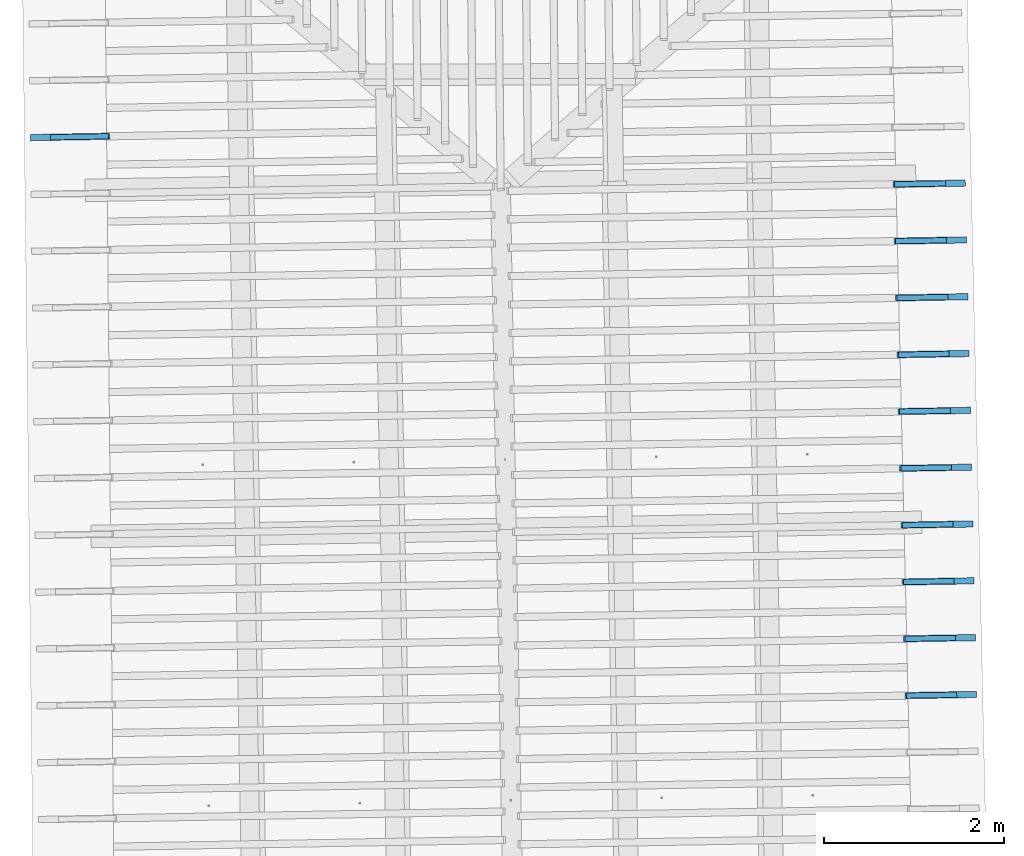
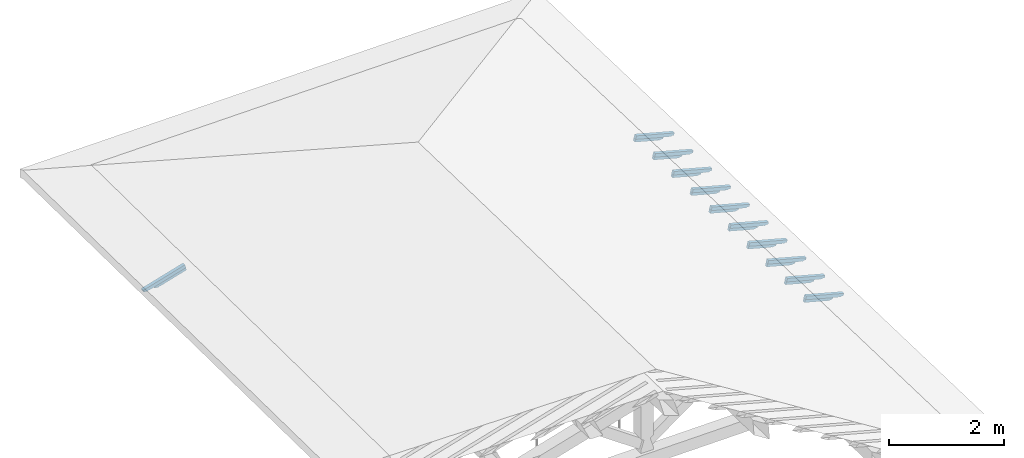
# One storey, part 14 of 19: 22 beams, 4 elements without a shape of their own.
"""IFC4 building model written with IfcOpenShell, lengths in metres."""

from ifc_helpers import new_model, entity, si_unit, converted_unit, derived_unit, direction, frame, origin, place, context, subcontext, project, spatial, line, arc, indexed_curve, outline, extrude, source, transform, mapped, material, type_object, type_shapes, element, aggregate, save


model = new_model("IFC4")

# Units and contexts
model_context = context("Model", 3, precision=1e-05, world=origin(), true_north=direction((6.123233995736766e-17, 1.0)))
body_context = subcontext(model_context, "Body", "Model", "MODEL_VIEW")
ifc_project = project(units=[si_unit("LENGTHUNIT", "METRE"), si_unit("AREAUNIT", "SQUARE_METRE"), si_unit("VOLUMEUNIT", "CUBIC_METRE"), converted_unit("PLANEANGLEUNIT", "DEGREE", entity("IfcPlaneAngleMeasure", 0.017453292519943278), si_unit("PLANEANGLEUNIT", "RADIAN"), dimensions=[0, 0, 0, 0, 0, 0, 0]), derived_unit("THERMALTRANSMITTANCEUNIT", [(si_unit("MASSUNIT", "GRAM", prefix="KILO"), 1), (si_unit("THERMODYNAMICTEMPERATUREUNIT", "KELVIN"), -1), (si_unit("TIMEUNIT", "SECOND"), -3)])], contexts=[model_context])

# Site, building, storey
site_placement = place(None, origin())
site = spatial("IfcSite", under=ifc_project, at=site_placement, CompositionType="ELEMENT")
building_placement = place(site_placement, origin())
building = spatial("IfcBuilding", under=site, at=building_placement, CompositionType="ELEMENT")
storey_placement = place(building_placement, frame((0.0, 0.0, 3.28)))
storey = spatial("IfcBuildingStorey", under=building, at=storey_placement, Name="Livello Copertura", CompositionType="ELEMENT", Elevation=3.28)

# Assembly, beam
assembly_1_placement = place(storey_placement, origin())
assembly_1 = element("IfcElementAssembly", 1, at=assembly_1_placement, inside=storey, Name="Sistema di travi strutturali:Sistema di travi strutturali", ObjectType="Sistema di travi strutturali:Sistema di travi strutturali", AssemblyPlace="NOTDEFINED", PredefinedType="BEAM_GRID")
ifc_material = material(Name="Legno - Legno da costruzione", Category="Legno")
beam_type_1 = type_object("IfcBeamType", Name="70x70:70x70", PredefinedType="JOIST", material=ifc_material)
shared_shape_1 = source(origin(), body_context, "Body", "SweptSolid", [
    extrude(outline(indexed_curve([(-0.04357142857143151, -0.5911428571428567), (0.026428571428568484, -0.5911428571428567), (0.026428571428568484, 0.1868571428571434), (0.012428571428584384, 0.18685714285714), (0.026181867029378903, 0.21056674738504463), (0.01842857142857075, 0.23685714285714354), (0.006014118110847714, 0.2598527183721264), (0.0034285714285709197, 0.28585714285714336), (-0.04357142857143151, 0.28585714285714336)], segments=[line(1, 2, 3, 4), arc(4, 5, 6), arc(6, 7, 8), line(8, 9, 1)], self_intersect=False)), frame((-0.11764285714285669, -0.03500000000000078, -0.008571428571433238), z_axis=(0.0, 1.0, 0.0), x_axis=(0.0, 0.0, -1.0)), (0.0, 0.0, 1.0), 0.06999999999999999),
])
type_shapes(beam_type_1, [shared_shape_1])
beam_1_placement = place(assembly_1_placement, frame((-5.117563232608936, 12.887914730478428, 0.11938629617812602), z_axis=(-0.26888056974925323, -0.004594467440668784, 0.9631625667976583), x_axis=(0.9630219859926786, 0.016455533263033686, 0.2689198206152652)))
beam_1 = element("IfcBeam", 2, at=beam_1_placement, type_object=beam_type_1, material=ifc_material, Name="70x70:70x70", ObjectType="70x70:70x70", PredefinedType="JOIST", context=body_context, shape_type="MappedRepresentation", body=[
    mapped(shared_shape_1, transform((0.0, 0.0, 0.0), scale=1.0)),
])
aggregate(assembly_1, [beam_1])

assembly_2_placement = place(storey_placement, origin())
assembly_2 = element("IfcElementAssembly", 3, at=assembly_2_placement, inside=storey, Name="Sistema di travi strutturali:Sistema di travi strutturali", ObjectType="Sistema di travi strutturali:Sistema di travi strutturali", AssemblyPlace="NOTDEFINED", PredefinedType="BEAM_GRID")
beam_type_2 = type_object("IfcBeamType", Name="60x60:60x60", PredefinedType="JOIST", material=ifc_material)
shared_shape_2 = source(origin(), body_context, "Body", "SweptSolid", [
    extrude(outline(indexed_curve([(-0.03585714285711799, -0.43985714285714317), (0.02414285714288199, -0.43985714285714317), (0.02414285714288199, 0.12814285714285706), (0.007142857142882057, 0.12814285714285706), (0.022800314198398987, 0.14573927319842478), (0.02014285714279457, 0.16914285714285818), (0.006097362558745775, 0.19729644559083798), (-0.003857142857204642, 0.227142857142857), (-0.03585714285711799, 0.2271428571428571)], segments=[line(1, 2, 3, 4), arc(4, 5, 6), arc(6, 7, 8), line(8, 9, 1)], self_intersect=False)), frame((0.03364285714285701, -0.030000000000000786, -0.005857142857119723), z_axis=(0.0, 1.0, 0.0), x_axis=(0.0, 0.0, -1.0)), (0.0, 0.0, 1.0), 0.059999999999999984),
])
type_shapes(beam_type_2, [shared_shape_2])
beam_2_placement = place(assembly_2_placement, frame((-5.100085995575236, 12.888213370862069, 0.056780729336277425), z_axis=(-0.26888056974925323, -0.004594467440668784, 0.9631625667976583), x_axis=(0.9630219859926786, 0.016455533263033686, 0.2689198206152652)))
beam_2 = element("IfcBeam", 4, at=beam_2_placement, type_object=beam_type_2, material=ifc_material, Name="60x60:60x60", ObjectType="60x60:60x60", PredefinedType="JOIST", context=body_context, shape_type="MappedRepresentation", body=[
    mapped(shared_shape_2, transform((0.0, 0.0, 0.0), scale=1.0)),
])
aggregate(assembly_2, [beam_2])

# Assembly, beams
assembly_3_placement = place(storey_placement, origin())
assembly_3 = element("IfcElementAssembly", 5, at=assembly_3_placement, inside=storey, Name="Sistema di travi strutturali:Sistema di travi strutturali", ObjectType="Sistema di travi strutturali:Sistema di travi strutturali", AssemblyPlace="NOTDEFINED", PredefinedType="BEAM_GRID")
beam_type_3 = type_object("IfcBeamType", Name="70x70:70x70", PredefinedType="JOIST", material=ifc_material)
shared_shape_3 = source(origin(), body_context, "Body", "SweptSolid", [
    extrude(outline(indexed_curve([(-0.043571428571431474, -0.5339999999999995), (0.026428571428568515, -0.5339999999999995), (0.026428571428568515, 0.16400000000000048), (0.012428571428584417, 0.1639999999999971), (0.02618186702937893, 0.18770960452790172), (0.018428571428570663, 0.21400000000000063), (0.006014118110847628, 0.23699557551498354), (0.0034285714285708334, 0.26300000000000046), (-0.043571428571431474, 0.26300000000000046)], segments=[line(1, 2, 3, 4), arc(4, 5, 6), arc(6, 7, 8), line(8, 9, 1)], self_intersect=False)), frame((-0.1004999999999995, -0.03500000000000078, -0.008571428571433207), z_axis=(0.0, 1.0, 0.0), x_axis=(0.0, 0.0, -1.0)), (0.0, 0.0, 1.0), 0.06999999999999999),
])
type_shapes(beam_type_3, [shared_shape_3])
beam_3_placement = place(assembly_3_placement, frame((4.4886432946279005, 12.371057575001064, 0.12287253880867066), z_axis=(0.2688805697492533, 0.004594467440668769, 0.9631625667976583), x_axis=(-0.9630219859926786, -0.016455533263030984, 0.2689198206152652)))
beam_3 = element("IfcBeam", 6, at=beam_3_placement, type_object=beam_type_3, material=ifc_material, Name="70x70:70x70", ObjectType="70x70:70x70", PredefinedType="JOIST", context=body_context, shape_type="MappedRepresentation", body=[
    mapped(shared_shape_3, transform((0.0, 0.0, 0.0), scale=1.0)),
])
beam_type_4 = type_object("IfcBeamType", Name="70x70:70x70", PredefinedType="JOIST", material=ifc_material)
shared_shape_4 = source(origin(), body_context, "Body", "SweptSolid", [
    extrude(outline(indexed_curve([(-0.04357142857143146, -0.5332857142857139), (0.026428571428568533, -0.5332857142857139), (0.026428571428568533, 0.16371428571428626), (0.012428571428584435, 0.16371428571428281), (0.026181867029378948, 0.18742389024218745), (0.018428571428570628, 0.2137142857142864), (0.006014118110847594, 0.23670986122926932), (0.003428571428570799, 0.26271428571428623), (-0.04357142857143146, 0.26271428571428623)], segments=[line(1, 2, 3, 4), arc(4, 5, 6), arc(6, 7, 8), line(8, 9, 1)], self_intersect=False)), frame((-0.10028571428571384, -0.03500000000000078, -0.00857142857143319), z_axis=(0.0, 1.0, 0.0), x_axis=(0.0, 0.0, -1.0)), (0.0, 0.0, 1.0), 0.06999999999999999),
])
type_shapes(beam_type_4, [shared_shape_4])
beam_4_placement = place(assembly_3_placement, frame((4.503091301204321, 11.74121248708805, 0.12184365175980783), z_axis=(0.2688805697492532, 0.0045944674406687685, 0.9631625667976583), x_axis=(-0.9630219859926786, -0.01645553326303173, 0.2689198206152651)))
beam_4 = element("IfcBeam", 7, at=beam_4_placement, type_object=beam_type_4, material=ifc_material, Name="70x70:70x70", ObjectType="70x70:70x70", PredefinedType="JOIST", context=body_context, shape_type="MappedRepresentation", body=[
    mapped(shared_shape_4, transform((0.0, 0.0, 0.0), scale=1.0)),
])
beam_5_placement = place(assembly_3_placement, frame((4.517539307780747, 11.111367399175041, 0.12081476471094454), z_axis=(0.26888056974925423, 0.004594467440668786, 0.9631625667976581), x_axis=(-0.9630219859926783, -0.0164555332630325, 0.26891982061526615)))
beam_5 = element("IfcBeam", 8, at=beam_5_placement, type_object=beam_type_4, material=ifc_material, Name="70x70:70x70", ObjectType="70x70:70x70", PredefinedType="JOIST", context=body_context, shape_type="MappedRepresentation", body=[
    mapped(shared_shape_4, transform((0.0, 0.0, 0.0), scale=1.0)),
])
beam_type_5 = type_object("IfcBeamType", Name="70x70:70x70", PredefinedType="JOIST", material=ifc_material)
shared_shape_5 = source(origin(), body_context, "Body", "SweptSolid", [
    extrude(outline(indexed_curve([(-0.043571428571431474, -0.5325714285714281), (0.026428571428568515, -0.5325714285714281), (0.026428571428568515, 0.16342857142857198), (0.012428571428584417, 0.1634285714285686), (0.02618186702937893, 0.18713817595647322), (0.018428571428570663, 0.2134285714285721), (0.006014118110847628, 0.236424146943555), (0.0034285714285708334, 0.26242857142857196), (-0.043571428571431474, 0.26242857142857196)], segments=[line(1, 2, 3, 4), arc(4, 5, 6), arc(6, 7, 8), line(8, 9, 1)], self_intersect=False)), frame((-0.1000714285714281, -0.03500000000000078, -0.008571428571433207), z_axis=(0.0, 1.0, 0.0), x_axis=(0.0, 0.0, -1.0)), (0.0, 0.0, 1.0), 0.06999999999999999),
])
type_shapes(beam_type_5, [shared_shape_5])
beam_6_placement = place(assembly_3_placement, frame((4.5319873143571705, 10.481522311262026, 0.11978587766208082), z_axis=(0.26888056974925306, 0.0045944674406687685, 0.9631625667976583), x_axis=(-0.9630219859926786, -0.01645553326303327, 0.26891982061526504)))
beam_6 = element("IfcBeam", 9, at=beam_6_placement, type_object=beam_type_5, material=ifc_material, Name="70x70:70x70", ObjectType="70x70:70x70", PredefinedType="JOIST", context=body_context, shape_type="MappedRepresentation", body=[
    mapped(shared_shape_5, transform((0.0, 0.0, 0.0), scale=1.0)),
])
beam_type_6 = type_object("IfcBeamType", Name="70x70:70x70", PredefinedType="JOIST", material=ifc_material)
shared_shape_6 = source(origin(), body_context, "Body", "SweptSolid", [
    extrude(outline(indexed_curve([(-0.04357142857143147, -0.5318571428571425), (0.026428571428568526, -0.5318571428571425), (0.026428571428568526, 0.16314285714285764), (0.012428571428584428, 0.16314285714285426), (0.026181867029378945, 0.18685246167075892), (0.01842857142857064, 0.2131428571428578), (0.006014118110847603, 0.2361384326578407), (0.0034285714285708087, 0.2621428571428576), (-0.04357142857143147, 0.2621428571428576)], segments=[line(1, 2, 3, 4), arc(4, 5, 6), arc(6, 7, 8), line(8, 9, 1)], self_intersect=False)), frame((-0.0998571428571424, -0.03500000000000078, -0.008571428571433197), z_axis=(0.0, 1.0, 0.0), x_axis=(0.0, 0.0, -1.0)), (0.0, 0.0, 1.0), 0.06999999999999999),
])
type_shapes(beam_type_6, [shared_shape_6])
beam_7_placement = place(assembly_3_placement, frame((4.546435320933593, 9.851677223349013, 0.1187569906132171), z_axis=(0.26888056974925306, 0.004594467440668767, 0.9631625667976583), x_axis=(-0.9630219859926786, -0.01645553326303402, 0.26891982061526504)))
beam_7 = element("IfcBeam", 10, at=beam_7_placement, type_object=beam_type_6, material=ifc_material, Name="70x70:70x70", ObjectType="70x70:70x70", PredefinedType="JOIST", context=body_context, shape_type="MappedRepresentation", body=[
    mapped(shared_shape_6, transform((0.0, 0.0, 0.0), scale=1.0)),
])
beam_type_7 = type_object("IfcBeamType", Name="70x70:70x70", PredefinedType="JOIST", material=ifc_material)
shared_shape_7 = source(origin(), body_context, "Body", "SweptSolid", [
    extrude(outline(indexed_curve([(-0.043571428571431516, -0.5311428571428567), (0.026428571428568474, -0.5311428571428567), (0.026428571428568474, 0.16285714285714334), (0.01242857142858438, 0.16285714285713995), (0.0261818670293789, 0.18656674738504458), (0.01842857142857076, 0.21285714285714347), (0.006014118110847725, 0.23585271837212637), (0.0034285714285709305, 0.2618571428571433), (-0.043571428571431516, 0.2618571428571433)], segments=[line(1, 2, 3, 4), arc(4, 5, 6), arc(6, 7, 8), line(8, 9, 1)], self_intersect=False)), frame((-0.09964285714285667, -0.03500000000000078, -0.008571428571433245), z_axis=(0.0, 1.0, 0.0), x_axis=(0.0, 0.0, -1.0)), (0.0, 0.0, 1.0), 0.06999999999999999),
])
type_shapes(beam_type_7, [shared_shape_7])
beam_8_placement = place(assembly_3_placement, frame((4.560883327510016, 9.221832135436001, 0.11772810356435515), z_axis=(0.2688805697492532, 0.0045944674406687685, 0.9631625667976583), x_axis=(-0.9630219859926786, -0.016455533263032313, 0.2689198206152651)))
beam_8 = element("IfcBeam", 11, at=beam_8_placement, type_object=beam_type_7, material=ifc_material, Name="70x70:70x70", ObjectType="70x70:70x70", PredefinedType="JOIST", context=body_context, shape_type="MappedRepresentation", body=[
    mapped(shared_shape_7, transform((0.0, 0.0, 0.0), scale=1.0)),
])
beam_9_placement = place(assembly_3_placement, frame((4.57533133408644, 8.591987047522988, 0.1166992165154912), z_axis=(0.26888056974925273, 0.00459446744066876, 0.9631625667976585), x_axis=(-0.9630219859926787, -0.01645553326303308, 0.26891982061526465)))
beam_9 = element("IfcBeam", 12, at=beam_9_placement, type_object=beam_type_7, material=ifc_material, Name="70x70:70x70", ObjectType="70x70:70x70", PredefinedType="JOIST", context=body_context, shape_type="MappedRepresentation", body=[
    mapped(shared_shape_7, transform((0.0, 0.0, 0.0), scale=1.0)),
])
beam_type_8 = type_object("IfcBeamType", Name="70x70:70x70", PredefinedType="JOIST", material=ifc_material)
shared_shape_8 = source(origin(), body_context, "Body", "SweptSolid", [
    extrude(outline(indexed_curve([(-0.04357142857143147, -0.5304285714285708), (0.0264285714285685, -0.5304285714285708), (0.0264285714285685, 0.16257142857142903), (0.012428571428584383, 0.16257142857142565), (0.0261818670293789, 0.1862810330993303), (0.018428571428570684, 0.2125714285714292), (0.006014118110847649, 0.2355670040864121), (0.003428571428570854, 0.261571428571429), (-0.04357142857143147, 0.261571428571429)], segments=[line(1, 2, 3, 4), arc(4, 5, 6), arc(6, 7, 8), line(8, 9, 1)], self_intersect=False)), frame((-0.09942857142857084, -0.03500000000000078, -0.00857142857143322), z_axis=(0.0, 1.0, 0.0), x_axis=(0.0, 0.0, -1.0)), (0.0, 0.0, 1.0), 0.06999999999999999),
])
type_shapes(beam_type_8, [shared_shape_8])
beam_10_placement = place(assembly_3_placement, frame((4.589779340662864, 7.962141959609977, 0.11567032946662792), z_axis=(0.26888056974925384, 0.004594467440668779, 0.9631625667976582), x_axis=(-0.9630219859926784, -0.016455533263032607, 0.26891982061526576)))
beam_10 = element("IfcBeam", 13, at=beam_10_placement, type_object=beam_type_8, material=ifc_material, Name="70x70:70x70", ObjectType="70x70:70x70", PredefinedType="JOIST", context=body_context, shape_type="MappedRepresentation", body=[
    mapped(shared_shape_8, transform((0.0, 0.0, 0.0), scale=1.0)),
])
beam_type_9 = type_object("IfcBeamType", Name="70x70:70x70", PredefinedType="JOIST", material=ifc_material)
shared_shape_9 = source(origin(), body_context, "Body", "SweptSolid", [
    extrude(outline(indexed_curve([(-0.04357142857143152, -0.5297142857142852), (0.026428571428568467, -0.5297142857142852), (0.026428571428568467, 0.16228571428571475), (0.012428571428584369, 0.16228571428571142), (0.026181867029378886, 0.18599531881361608), (0.018428571428570784, 0.21228571428571488), (0.006014118110847748, 0.2352812898006978), (0.003428571428570954, 0.26128571428571473), (-0.04357142857143152, 0.26128571428571473)], segments=[line(1, 2, 3, 4), arc(4, 5, 6), arc(6, 7, 8), line(8, 9, 1)], self_intersect=False)), frame((-0.09921428571428524, -0.03500000000000078, -0.008571428571433256), z_axis=(0.0, 1.0, 0.0), x_axis=(0.0, 0.0, -1.0)), (0.0, 0.0, 1.0), 0.06999999999999999),
])
type_shapes(beam_type_9, [shared_shape_9])
beam_11_placement = place(assembly_3_placement, frame((4.604227347239287, 7.3322968716969665, 0.11464144241776353), z_axis=(0.26888056974925284, 0.0045944674406687615, 0.9631625667976584), x_axis=(-0.9630219859926787, -0.016455533263032122, 0.26891982061526476)))
beam_11 = element("IfcBeam", 14, at=beam_11_placement, type_object=beam_type_9, material=ifc_material, Name="70x70:70x70", ObjectType="70x70:70x70", PredefinedType="JOIST", context=body_context, shape_type="MappedRepresentation", body=[
    mapped(shared_shape_9, transform((0.0, 0.0, 0.0), scale=1.0)),
])
beam_type_10 = type_object("IfcBeamType", Name="70x70:70x70", PredefinedType="JOIST", material=ifc_material)
shared_shape_10 = source(origin(), body_context, "Body", "SweptSolid", [
    extrude(outline(indexed_curve([(-0.043571428571431495, -0.5289999999999996), (0.026428571428568474, -0.5289999999999996), (0.026428571428568474, 0.1620000000000005), (0.01242857142858435, 0.16199999999999715), (0.026181867029378865, 0.18570960452790178), (0.018428571428570757, 0.21200000000000063), (0.006014118110847721, 0.23499557551498354), (0.003428571428570926, 0.26100000000000045), (-0.043571428571431495, 0.26100000000000045)], segments=[line(1, 2, 3, 4), arc(4, 5, 6), arc(6, 7, 8), line(8, 9, 1)], self_intersect=False)), frame((-0.09899999999999946, -0.03500000000000078, -0.008571428571433249), z_axis=(0.0, 1.0, 0.0), x_axis=(0.0, 0.0, -1.0)), (0.0, 0.0, 1.0), 0.06999999999999999),
])
type_shapes(beam_type_10, [shared_shape_10])
beam_12_placement = place(assembly_3_placement, frame((4.618675353815711, 6.702451783783954, 0.11361255536890003), z_axis=(0.2688805697492532, 0.0045944674406687685, 0.9631625667976583), x_axis=(-0.9630219859926786, -0.01645553326303164, 0.26891982061526515)))
beam_12 = element("IfcBeam", 15, at=beam_12_placement, type_object=beam_type_10, material=ifc_material, Name="70x70:70x70", ObjectType="70x70:70x70", PredefinedType="JOIST", context=body_context, shape_type="MappedRepresentation", body=[
    mapped(shared_shape_10, transform((0.0, 0.0, 0.0), scale=1.0)),
])
aggregate(assembly_3, [beam_3, beam_4, beam_5, beam_6, beam_7, beam_8, beam_9, beam_10, beam_11, beam_12])

assembly_4_placement = place(storey_placement, origin())
assembly_4 = element("IfcElementAssembly", 16, at=assembly_4_placement, inside=storey, Name="Sistema di travi strutturali:Sistema di travi strutturali", ObjectType="Sistema di travi strutturali:Sistema di travi strutturali", AssemblyPlace="NOTDEFINED", PredefinedType="BEAM_GRID")
beam_type_11 = type_object("IfcBeamType", Name="60x60:60x60", PredefinedType="JOIST", material=ifc_material)
shared_shape_11 = source(origin(), body_context, "Body", "SweptSolid", [
    extrude(outline(indexed_curve([(-0.03585714285711755, -0.38271428571428584), (0.02414285714288243, -0.38271428571428584), (0.02414285714288243, 0.10528571428571411), (0.007142857142882492, 0.10528571428571411), (0.022800314198399424, 0.12288213034128184), (0.020142857142793485, 0.14628571428571524), (0.006097362558744688, 0.174439302733695), (-0.0038571428572057287, 0.20428571428571407), (-0.03585714285711755, 0.20428571428571413)], segments=[line(1, 2, 3, 4), arc(4, 5, 6), arc(6, 7, 8), line(8, 9, 1)], self_intersect=False)), frame((0.05078571428571418, -0.030000000000000786, -0.005857142857119288), z_axis=(0.0, 1.0, 0.0), x_axis=(0.0, 0.0, -1.0)), (0.0, 0.0, 1.0), 0.059999999999999984),
])
type_shapes(beam_type_11, [shared_shape_11])
beam_13_placement = place(assembly_4_placement, frame((4.471166057594199, 12.370758934617422, 0.060266971966822735), z_axis=(0.2688805697492535, 0.004594467440668775, 0.9631625667976582), x_axis=(-0.9630219859926786, -0.01645553326303096, 0.2689198206152655)))
beam_13 = element("IfcBeam", 17, at=beam_13_placement, type_object=beam_type_11, material=ifc_material, Name="60x60:60x60", ObjectType="60x60:60x60", PredefinedType="JOIST", context=body_context, shape_type="MappedRepresentation", body=[
    mapped(shared_shape_11, transform((0.0, 0.0, 0.0), scale=1.0)),
])
beam_type_12 = type_object("IfcBeamType", Name="60x60:60x60", PredefinedType="JOIST", material=ifc_material)
shared_shape_12 = source(origin(), body_context, "Body", "SweptSolid", [
    extrude(outline(indexed_curve([(-0.03585714285711767, -0.3820000000000003), (0.024142857142882314, -0.3820000000000003), (0.024142857142882314, 0.10499999999999989), (0.007142857142882376, 0.10499999999999989), (0.02280031419839931, 0.12259641605556762), (0.020142857142793777, 0.14600000000000102), (0.006097362558744978, 0.17415358844798082), (-0.003857142857205439, 0.20399999999999985), (-0.03585714285711767, 0.20399999999999993)], segments=[line(1, 2, 3, 4), arc(4, 5, 6), arc(6, 7, 8), line(8, 9, 1)], self_intersect=False)), frame((0.050999999999999844, -0.030000000000000786, -0.005857142857119404), z_axis=(0.0, 1.0, 0.0), x_axis=(0.0, 0.0, -1.0)), (0.0, 0.0, 1.0), 0.059999999999999984),
])
type_shapes(beam_type_12, [shared_shape_12])
beam_14_placement = place(assembly_4_placement, frame((4.485614064170621, 11.740913846704409, 0.05923808491796012), z_axis=(0.2688805697492532, 0.0045944674406687685, 0.9631625667976583), x_axis=(-0.9630219859926786, -0.01645553326303173, 0.2689198206152651)))
beam_14 = element("IfcBeam", 18, at=beam_14_placement, type_object=beam_type_12, material=ifc_material, Name="60x60:60x60", ObjectType="60x60:60x60", PredefinedType="JOIST", context=body_context, shape_type="MappedRepresentation", body=[
    mapped(shared_shape_12, transform((0.0, 0.0, 0.0), scale=1.0)),
])
beam_15_placement = place(assembly_4_placement, frame((4.5000620707470445, 11.111068758791392, 0.05820919786909662), z_axis=(0.2688805697492538, 0.004594467440668778, 0.9631625667976582), x_axis=(-0.9630219859926785, -0.016455533263032514, 0.26891982061526576)))
beam_15 = element("IfcBeam", 19, at=beam_15_placement, type_object=beam_type_12, material=ifc_material, Name="60x60:60x60", ObjectType="60x60:60x60", PredefinedType="JOIST", context=body_context, shape_type="MappedRepresentation", body=[
    mapped(shared_shape_12, transform((0.0, 0.0, 0.0), scale=1.0)),
])
beam_type_13 = type_object("IfcBeamType", Name="60x60:60x60", PredefinedType="JOIST", material=ifc_material)
shared_shape_13 = source(origin(), body_context, "Body", "SweptSolid", [
    extrude(outline(indexed_curve([(-0.035857142857117746, -0.3812857142857145), (0.024142857142882237, -0.3812857142857145), (0.024142857142882237, 0.1047142857142856), (0.007142857142882299, 0.1047142857142856), (0.022800314198399233, 0.12231070176985331), (0.02014285714279397, 0.14571428571428674), (0.006097362558745171, 0.1738678741622665), (-0.0038571428572052456, 0.20371428571428557), (-0.035857142857117746, 0.20371428571428563)], segments=[line(1, 2, 3, 4), arc(4, 5, 6), arc(6, 7, 8), line(8, 9, 1)], self_intersect=False)), frame((0.051214285714285566, -0.030000000000000786, -0.005857142857119481), z_axis=(0.0, 1.0, 0.0), x_axis=(0.0, 0.0, -1.0)), (0.0, 0.0, 1.0), 0.059999999999999984),
])
type_shapes(beam_type_13, [shared_shape_13])
beam_16_placement = place(assembly_4_placement, frame((4.51451007732347, 10.481223670878382, 0.057180310820233116), z_axis=(0.2688805697492537, 0.004594467440668775, 0.9631625667976583), x_axis=(-0.9630219859926785, -0.016455533263033256, 0.2689198206152656)))
beam_16 = element("IfcBeam", 20, at=beam_16_placement, type_object=beam_type_13, material=ifc_material, Name="60x60:60x60", ObjectType="60x60:60x60", PredefinedType="JOIST", context=body_context, shape_type="MappedRepresentation", body=[
    mapped(shared_shape_13, transform((0.0, 0.0, 0.0), scale=1.0)),
])
beam_type_14 = type_object("IfcBeamType", Name="60x60:60x60", PredefinedType="JOIST", material=ifc_material)
shared_shape_14 = source(origin(), body_context, "Body", "SweptSolid", [
    extrude(outline(indexed_curve([(-0.035857142857116775, -0.38057142857142884), (0.024142857142883205, -0.38057142857142884), (0.024142857142883205, 0.10442857142857137), (0.007142857142883392, 0.10442857142857148), (0.022800314198400326, 0.12202498748413922), (0.020142857142791487, 0.14542857142857227), (0.0060973625587426895, 0.17358215987655207), (-0.0038571428572077276, 0.2034285714285711), (-0.035857142857116775, 0.2034285714285715)], segments=[line(1, 2, 3, 4), arc(4, 5, 6), arc(6, 7, 8), line(8, 9, 1)], self_intersect=False)), frame((0.05142857142857124, -0.030000000000000786, -0.005857142857118512), z_axis=(0.0, 1.0, 0.0), x_axis=(0.0, 0.0, -1.0)), (0.0, 0.0, 1.0), 0.059999999999999984),
])
type_shapes(beam_type_14, [shared_shape_14])
beam_17_placement = place(assembly_4_placement, frame((4.528958083899893, 9.851378582965374, 0.05615142377136917), z_axis=(0.26888056974925334, 0.0045944674406687685, 0.9631625667976584), x_axis=(-0.9630219859926786, -0.016455533263034065, 0.26891982061526526)))
beam_17 = element("IfcBeam", 21, at=beam_17_placement, type_object=beam_type_14, material=ifc_material, Name="60x60:60x60", ObjectType="60x60:60x60", PredefinedType="JOIST", context=body_context, shape_type="MappedRepresentation", body=[
    mapped(shared_shape_14, transform((0.0, 0.0, 0.0), scale=1.0)),
])
beam_type_15 = type_object("IfcBeamType", Name="60x60:60x60", PredefinedType="JOIST", material=ifc_material)
shared_shape_15 = source(origin(), body_context, "Body", "SweptSolid", [
    extrude(outline(indexed_curve([(-0.035857142857117975, -0.379857142857143), (0.024142857142882005, -0.379857142857143), (0.024142857142882005, 0.10414285714285698), (0.007142857142882067, 0.10414285714285698), (0.022800314198399, 0.12173927319842472), (0.02014285714279455, 0.14514285714285813), (0.006097362558745752, 0.1732964455908379), (-0.003857142857204665, 0.20314285714285696), (-0.035857142857117975, 0.20314285714285701)], segments=[line(1, 2, 3, 4), arc(4, 5, 6), arc(6, 7, 8), line(8, 9, 1)], self_intersect=False)), frame((0.05164285714285701, -0.030000000000000786, -0.005857142857119713), z_axis=(0.0, 1.0, 0.0), x_axis=(0.0, 0.0, -1.0)), (0.0, 0.0, 1.0), 0.059999999999999984),
])
type_shapes(beam_type_15, [shared_shape_15])
beam_18_placement = place(assembly_4_placement, frame((4.543406090476315, 9.221533495052359, 0.055122536722506776), z_axis=(0.2688805697492532, 0.00459446744066877, 0.9631625667976583), x_axis=(-0.9630219859926786, -0.016455533263032313, 0.2689198206152651)))
beam_18 = element("IfcBeam", 22, at=beam_18_placement, type_object=beam_type_15, material=ifc_material, Name="60x60:60x60", ObjectType="60x60:60x60", PredefinedType="JOIST", context=body_context, shape_type="MappedRepresentation", body=[
    mapped(shared_shape_15, transform((0.0, 0.0, 0.0), scale=1.0)),
])
beam_19_placement = place(assembly_4_placement, frame((4.557854097052738, 8.591688407139348, 0.05409364967364283), z_axis=(0.2688805697492535, 0.004594467440668775, 0.9631625667976582), x_axis=(-0.9630219859926785, -0.016455533263031837, 0.2689198206152654)))
beam_19 = element("IfcBeam", 23, at=beam_19_placement, type_object=beam_type_15, material=ifc_material, Name="60x60:60x60", ObjectType="60x60:60x60", PredefinedType="JOIST", context=body_context, shape_type="MappedRepresentation", body=[
    mapped(shared_shape_15, transform((0.0, 0.0, 0.0), scale=1.0)),
])
beam_type_16 = type_object("IfcBeamType", Name="60x60:60x60", PredefinedType="JOIST", material=ifc_material)
shared_shape_16 = source(origin(), body_context, "Body", "SweptSolid", [
    extrude(outline(indexed_curve([(-0.03585714285711765, -0.37914285714285734), (0.02414285714288233, -0.37914285714285734), (0.02414285714288233, 0.1038571428571427), (0.007142857142882395, 0.1038571428571427), (0.022800314198399327, 0.12145355891271041), (0.020142857142793725, 0.14485714285714382), (0.006097362558744929, 0.17301073130512362), (-0.0038571428572054876, 0.20285714285714265), (-0.03585714285711765, 0.20285714285714274)], segments=[line(1, 2, 3, 4), arc(4, 5, 6), arc(6, 7, 8), line(8, 9, 1)], self_intersect=False)), frame((0.051857142857142734, -0.030000000000000786, -0.005857142857119385), z_axis=(0.0, 1.0, 0.0), x_axis=(0.0, 0.0, -1.0)), (0.0, 0.0, 1.0), 0.059999999999999984),
])
type_shapes(beam_type_16, [shared_shape_16])
beam_20_placement = place(assembly_4_placement, frame((4.572302103629164, 7.961843319226334, 0.05306476262477977), z_axis=(0.26888056974925323, 0.004594467440668771, 0.9631625667976583), x_axis=(-0.9630219859926786, -0.016455533263032607, 0.2689198206152652)))
beam_20 = element("IfcBeam", 24, at=beam_20_placement, type_object=beam_type_16, material=ifc_material, Name="60x60:60x60", ObjectType="60x60:60x60", PredefinedType="JOIST", context=body_context, shape_type="MappedRepresentation", body=[
    mapped(shared_shape_16, transform((0.0, 0.0, 0.0), scale=1.0)),
])
beam_type_17 = type_object("IfcBeamType", Name="60x60:60x60", PredefinedType="JOIST", material=ifc_material)
shared_shape_17 = source(origin(), body_context, "Body", "SweptSolid", [
    extrude(outline(indexed_curve([(-0.03585714285711763, -0.37842857142857156), (0.024142857142882352, -0.37842857142857156), (0.024142857142882352, 0.1035714285714284), (0.007142857142882415, 0.1035714285714284), (0.022800314198399348, 0.12116784462699613), (0.02014285714279368, 0.14457142857142952), (0.006097362558744881, 0.17272501701940932), (-0.0038571428572055353, 0.20257142857142835), (-0.03585714285711763, 0.2025714285714284)], segments=[line(1, 2, 3, 4), arc(4, 5, 6), arc(6, 7, 8), line(8, 9, 1)], self_intersect=False)), frame((0.05207142857142846, -0.030000000000000786, -0.005857142857119365), z_axis=(0.0, 1.0, 0.0), x_axis=(0.0, 0.0, -1.0)), (0.0, 0.0, 1.0), 0.059999999999999984),
])
type_shapes(beam_type_17, [shared_shape_17])
beam_21_placement = place(assembly_4_placement, frame((4.586750110205586, 7.331998231313322, 0.0520358755759156), z_axis=(0.26888056974925345, 0.004594467440668773, 0.9631625667976582), x_axis=(-0.9630219859926785, -0.016455533263032122, 0.26891982061526537)))
beam_21 = element("IfcBeam", 25, at=beam_21_placement, type_object=beam_type_17, material=ifc_material, Name="60x60:60x60", ObjectType="60x60:60x60", PredefinedType="JOIST", context=body_context, shape_type="MappedRepresentation", body=[
    mapped(shared_shape_17, transform((0.0, 0.0, 0.0), scale=1.0)),
])
beam_type_18 = type_object("IfcBeamType", Name="60x60:60x60", PredefinedType="JOIST", material=ifc_material)
shared_shape_18 = source(origin(), body_context, "Body", "SweptSolid", [
    extrude(outline(indexed_curve([(-0.035857142857117975, -0.377714285714286), (0.024142857142882005, -0.377714285714286), (0.024142857142882005, 0.10328571428571418), (0.007142857142882067, 0.10328571428571418), (0.022800314198399, 0.12088213034128191), (0.02014285714279455, 0.14428571428571532), (0.006097362558745752, 0.1724393027336951), (-0.003857142857204665, 0.20228571428571412), (-0.035857142857117975, 0.20228571428571418)], segments=[line(1, 2, 3, 4), arc(4, 5, 6), arc(6, 7, 8), line(8, 9, 1)], self_intersect=False)), frame((0.05228571428571412, -0.030000000000000786, -0.005857142857119713), z_axis=(0.0, 1.0, 0.0), x_axis=(0.0, 0.0, -1.0)), (0.0, 0.0, 1.0), 0.059999999999999984),
])
type_shapes(beam_type_18, [shared_shape_18])
beam_22_placement = place(assembly_4_placement, frame((4.601198116782011, 6.70215314340031, 0.0510069885270521), z_axis=(0.2688805697492532, 0.0045944674406687685, 0.9631625667976583), x_axis=(-0.9630219859926786, -0.01645553326303164, 0.26891982061526515)))
beam_22 = element("IfcBeam", 26, at=beam_22_placement, type_object=beam_type_18, material=ifc_material, Name="60x60:60x60", ObjectType="60x60:60x60", PredefinedType="JOIST", context=body_context, shape_type="MappedRepresentation", body=[
    mapped(shared_shape_18, transform((0.0, 0.0, 0.0), scale=1.0)),
])
aggregate(assembly_4, [beam_13, beam_14, beam_15, beam_16, beam_17, beam_18, beam_19, beam_20, beam_21, beam_22])

save(model, "model.ifc")
